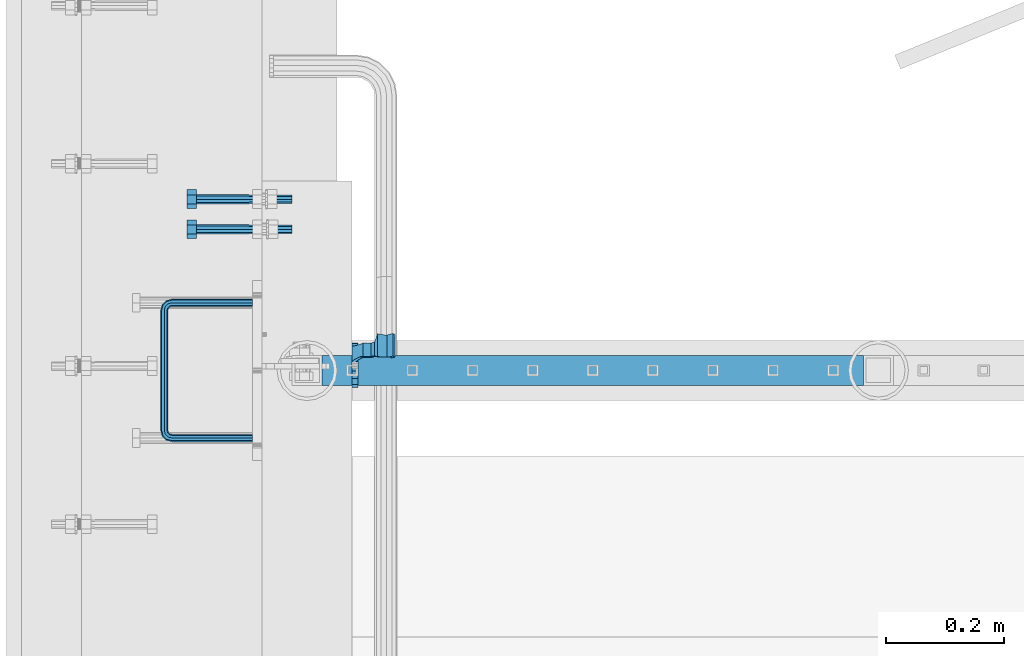
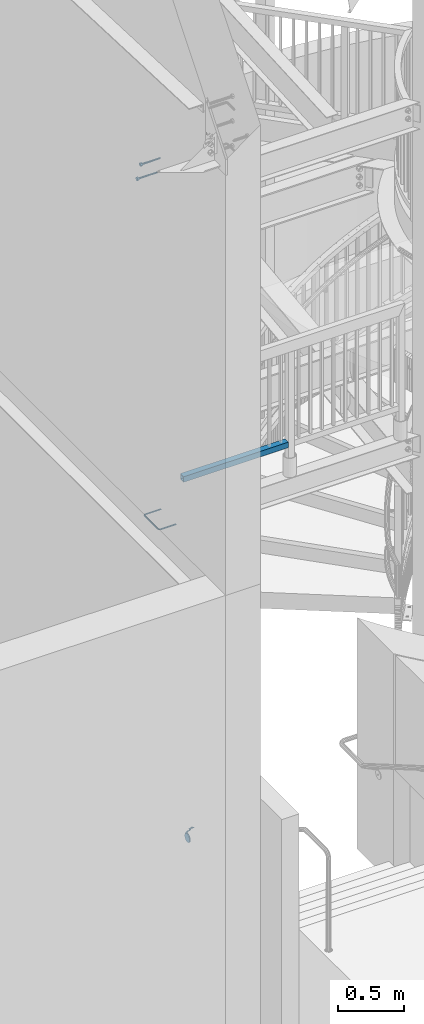
# One storey, part 456 of 975: 5 beams.
"""IFC2X3 building model written with IfcOpenShell, lengths in millimetres."""

import ifcopenshell
import ifcopenshell.guid

model = None  # the IFC model being written
_history = None  # IfcOwnerHistory: only IFC2X3 demands one
_inside = {}  # id of a spatial element -> (the spatial element, [elements in it])
_under = {}  # id of a project, library or spatial element -> (it, [spatial elements below it])
_declared = {}  # id of a project -> (the project, [libraries it declares])
_typed = {}  # id of a type object -> (the type object, [elements of that type])
_made_of = {}  # id of a material, layer set ... -> (it, [elements and type objects made of it])


def new_model(schema):
    """Start an empty IFC model of exactly this schema.

    Asked for "IFC4X3", IfcOpenShell would pick the latest addendum, in which some entities
    have other attributes; the version numbers below select the first issue.
    IFC2X3 requires an IfcOwnerHistory on every rooted entity: one is made here for all.
    """
    global model, _history
    if schema == "IFC4X3":
        model = ifcopenshell.file(schema_version=(4, 3, 0, 0))
    else:
        model = ifcopenshell.file(schema=schema)
    _inside.clear()
    _under.clear()
    _declared.clear()
    _typed.clear()
    _made_of.clear()
    _history = None
    if model.schema == "IFC2X3":
        org = make("IfcOrganization", Name="unknown")
        user = make(
            "IfcPersonAndOrganization",
            ThePerson=make("IfcPerson", FamilyName="unknown"),
            TheOrganization=org,
        )
        app = make(
            "IfcApplication",
            ApplicationDeveloper=org,
            Version="unknown",
            ApplicationFullName="unknown",
            ApplicationIdentifier="unknown",
        )
        _history = make(
            "IfcOwnerHistory",
            OwningUser=user,
            OwningApplication=app,
            ChangeAction="ADDED",
            CreationDate=0,
        )
    return model


def make(cls, **values):
    """One entity of the class cls with the attributes given. An attribute that is None is left unset."""
    return model.create_entity(
        cls, **{name: value for name, value in values.items() if value is not None}
    )


def rooted(cls, **values):
    """An entity with a GlobalId (a new one), such as an element, a storey or a relation."""
    return make(cls, GlobalId=ifcopenshell.guid.new(), OwnerHistory=_history, **values)


def si_unit(unit_type, name, prefix=None):
    """IfcSIUnit, for example si_unit("LENGTHUNIT", "METRE", prefix="MILLI")."""
    return make("IfcSIUnit", UnitType=unit_type, Prefix=prefix, Name=name)


def assignment(units):
    """IfcUnitAssignment: the units of a project."""
    return None if units is None else make("IfcUnitAssignment", Units=units)


def point(xyz):
    """IfcCartesianPoint."""
    return None if xyz is None else make("IfcCartesianPoint", Coordinates=xyz)


def direction(xyz):
    """IfcDirection."""
    return None if xyz is None else make("IfcDirection", DirectionRatios=xyz)


def frame(location, z_axis=None, x_axis=None):
    """IfcAxis2Placement3D, a coordinate frame: its origin and axes. An axis left out is left unset."""
    return make(
        "IfcAxis2Placement3D",
        Location=point(location),
        Axis=direction(z_axis),
        RefDirection=direction(x_axis),
    )


def origin_with_axes():
    """The frame at (0, 0, 0) with the z axis (0, 0, 1) and the x axis (1, 0, 0) written out."""
    return frame((0.0, 0.0, 0.0), z_axis=(0.0, 0.0, 1.0), x_axis=(1.0, 0.0, 0.0))


def place(relative_to, where):
    """IfcLocalPlacement: puts the frame where relative to a parent placement (None: the world)."""
    return make(
        "IfcLocalPlacement", PlacementRelTo=relative_to, RelativePlacement=where
    )


def context(
    kind, dimensions, precision=None, world=None, true_north=None, identifier=None
):
    """IfcGeometricRepresentationContext, for example the 3D "Model" context."""
    return make(
        "IfcGeometricRepresentationContext",
        ContextIdentifier=identifier,
        ContextType=kind,
        CoordinateSpaceDimension=dimensions,
        Precision=precision,
        WorldCoordinateSystem=world,
        TrueNorth=true_north,
    )


def subcontext(parent, identifier, kind, view, scale=None):
    """IfcGeometricRepresentationSubContext, for example "Body" below "Model"."""
    return make(
        "IfcGeometricRepresentationSubContext",
        ContextIdentifier=identifier,
        ContextType=kind,
        ParentContext=parent,
        TargetScale=scale,
        TargetView=view,
    )


def project(units=None, contexts=None):
    """IfcProject with its units and contexts."""
    return rooted(
        "IfcProject",
        Name="project",
        RepresentationContexts=contexts,
        UnitsInContext=assignment(units),
    )


def spatial(cls, under=None, at=None, **own):
    """A site, building, storey or space (cls), placed at a placement, below another one or the project."""
    s = rooted(cls, ObjectPlacement=at, **own)
    if under is not None:
        _under.setdefault(under.id(), (under, []))[1].append(s)
    return s


def faces_of(points, faces, orient=None, outer=None):
    """IfcFace entities. A face is a list of loops; a loop is a list of indices into points, from 0.

    orient and outer hold one flag for each loop. By default every Orientation is true, the
    first loop of a face is its IfcFaceOuterBound and the others are IfcFaceBound.
    """
    made = []
    for i, loops in enumerate(faces):
        bounds = []
        for j, loop in enumerate(loops):
            is_outer = j == 0 if outer is None else outer[i][j]
            bounds.append(
                make(
                    "IfcFaceOuterBound" if is_outer else "IfcFaceBound",
                    Bound=make("IfcPolyLoop", Polygon=[points[k] for k in loop]),
                    Orientation=True if orient is None else orient[i][j],
                )
            )
        made.append(make("IfcFace", Bounds=bounds))
    return made


def faceted_brep(points, faces, orient=None, outer=None, voids=None):
    """IfcFacetedBrep: a solid bounded by flat faces; with voids (closed shells), ...WithVoids."""
    shared = [point(p) for p in points]
    hull = make("IfcClosedShell", CfsFaces=faces_of(shared, faces, orient, outer))
    if voids is None:
        return make("IfcFacetedBrep", Outer=hull)
    return make(
        "IfcFacetedBrepWithVoids",
        Outer=hull,
        Voids=[
            make(cls, CfsFaces=faces_of(shared, fs, o, b)) for cls, fs, o, b in voids
        ],
    )


def shape(context_of_items, identifier, shape_type, items):
    """IfcShapeRepresentation: the items that make up one representation, for example the "Body"."""
    return make(
        "IfcShapeRepresentation",
        ContextOfItems=context_of_items,
        RepresentationIdentifier=identifier,
        RepresentationType=shape_type,
        Items=items,
    )


def material(Name=None, Category=None):
    """IfcMaterial."""
    return make("IfcMaterial", Name=Name, Category=Category)


def made_of(thing, what):
    """Note that an element or type object is made of a material, layer set ...; save() writes the relation."""
    if what is not None:
        _made_of.setdefault(what.id(), (what, []))[1].append(thing)
    return thing


def type_object(cls, material=None, **own):
    """A type object (cls), such as IfcWallType, which elements share."""
    return made_of(rooted(cls, **own), material)


def element(
    cls,
    number,
    at=None,
    inside=None,
    cuts=None,
    type_object=None,
    material=None,
    context=None,
    identifier="Body",
    shape_type=None,
    held_by="IfcProductDefinitionShape",
    body=None,
    shapes=None,
    **own,
):
    """One element of the class cls, such as IfcWall. Its Tag is "e" and its number.

    at: its placement. inside: the storey or other place that contains it. cuts: it is an
    opening in that element (IfcRelVoidsElement). A single representation is given by context,
    identifier, shape_type and body (its items); several are given by shapes. held_by: the class
    of the entity that holds the representations. save() writes the other relations.
    """
    e = rooted(cls, Tag="e%d" % number, ObjectPlacement=at, **own)
    if body is not None:
        shapes = [shape(context, identifier, shape_type, body)]
    if shapes is not None:
        e.Representation = make(held_by, Representations=shapes)
    if inside is not None:
        _inside.setdefault(inside.id(), (inside, []))[1].append(e)
    if cuts is not None:
        rooted(
            "IfcRelVoidsElement", RelatingBuildingElement=cuts, RelatedOpeningElement=e
        )
    if type_object is not None:
        _typed.setdefault(type_object.id(), (type_object, []))[1].append(e)
    return made_of(e, material)


def aggregate(whole, parts):
    """IfcRelAggregates: a whole, such as a stair, and the parts it consists of."""
    return rooted("IfcRelAggregates", RelatingObject=whole, RelatedObjects=parts)


def save(model, path):
    """Write the relations noted so far, then the file.

    IfcRelAggregates (storeys below a building ...), IfcRelContainedInSpatialStructure (elements
    in a storey), IfcRelDefinesByType, IfcRelAssociatesMaterial and IfcRelDeclares: one each for
    every whole, place, type object, material and project.
    """
    for whole, parts in _under.values():
        aggregate(whole, parts)
    for where, things in _inside.values():
        rooted(
            "IfcRelContainedInSpatialStructure",
            RelatedElements=things,
            RelatingStructure=where,
        )
    for kind, things in _typed.values():
        rooted("IfcRelDefinesByType", RelatedObjects=things, RelatingType=kind)
    for what, things in _made_of.values():
        rooted("IfcRelAssociatesMaterial", RelatedObjects=things, RelatingMaterial=what)
    for by, libraries in _declared.values():
        rooted("IfcRelDeclares", RelatingContext=by, RelatedDefinitions=libraries)
    model.write(path)


model = new_model("IFC2X3")

# Units and contexts
model_context = context("Model", 3, precision=1e-05, world=origin_with_axes())
body_context = subcontext(model_context, "Body", "Model", "MODEL_VIEW")
ifc_project = project(units=[si_unit("LENGTHUNIT", "METRE", prefix="MILLI"), si_unit("AREAUNIT", "SQUARE_METRE"), si_unit("VOLUMEUNIT", "CUBIC_METRE"), si_unit("MASSUNIT", "GRAM", prefix="KILO"), si_unit("TIMEUNIT", "SECOND"), si_unit("PLANEANGLEUNIT", "RADIAN"), si_unit("SOLIDANGLEUNIT", "STERADIAN"), si_unit("THERMODYNAMICTEMPERATUREUNIT", "DEGREE_CELSIUS"), si_unit("LUMINOUSINTENSITYUNIT", "LUMEN")], contexts=[model_context])

# Site, building, storey
site_placement = place(None, origin_with_axes())
site = spatial("IfcSite", under=ifc_project, at=site_placement, CompositionType="ELEMENT")
building_placement = place(site_placement, origin_with_axes())
building = spatial("IfcBuilding", under=site, at=building_placement, Name="Undefined", CompositionType="ELEMENT")
storey_placement = place(building_placement, origin_with_axes())
storey = spatial("IfcBuildingStorey", under=building, at=storey_placement, Name="Undefined", CompositionType="ELEMENT", Elevation=0.0)

# Beams
ifc_material_1 = material()
beam_type_1 = type_object("IfcBeamType", Name="HSS2X2X.188_TUBES", PredefinedType="NOTDEFINED")
beam_1_placement = place(storey_placement, frame((30035.4999840149, 1364.89231756838, 4229.10021228673), z_axis=(5.69299999915529e-06, 0.999999999983795, 0.0), x_axis=(0.999999999983699, -5.6929999999029e-06, -4.37999999618523e-07)))
element("IfcBeam", 1, at=beam_1_placement, inside=storey, type_object=beam_type_1, material=ifc_material_1, Name="HANDRAIL", ObjectType="HSS2X2X.188_TUBES", context=body_context, shape_type="Brep", body=[
    faceted_brep([(25.4001425128263, 20.6374999999998, -20.6375000000021), (25.4001244344508, -20.6375000000044, -20.6375000000025), (940.579801494787, -20.6375000000808, -20.6375000000469), (940.579790102809, 20.6374999999234, -20.6375000000467), (25.3998894558863, -20.6375000000044, 20.6375), (940.579566516219, -20.6375000000808, 20.6374999999555), (25.3999075342581, 20.6374999999998, 20.6375000000003), (940.579555124245, 20.6374999999234, 20.6374999999559), (25.4001717116989, 25.3999999999996, -25.4000000000026), (25.3998825073104, 25.4000000000005, 25.4000000000005), (940.579526696874, 25.3999999999232, 25.3999999999562), (940.579815901263, 25.3999999999232, -25.4000000000469), (25.3998602570064, -25.4000000000033, 25.4000000000001), (940.579540717765, -25.4000000000815, 25.399999999956), (25.4001494613913, -25.4000000000042, -25.4000000000028), (940.579829922153, -25.4000000000806, -25.4000000000474)], [[[0, 1, 2, 3]], [[1, 4, 5, 2]], [[4, 6, 7, 5]], [[6, 0, 3, 7]], [[8, 9, 10, 11]], [[9, 12, 13, 10]], [[12, 14, 15, 13]], [[14, 8, 11, 15]], [[13, 15, 11, 10], [5, 7, 3, 2]], [[14, 12, 9, 8], [6, 4, 1, 0]]]),
])
ifc_material_2 = material(Name="STEEL/A36")
beam_type_2 = type_object("IfcBeamType", PredefinedType="NOTDEFINED")
beam_2_placement = place(storey_placement, frame((30121.225030483, 1373.95484456894, 883.216794476958), z_axis=(0.0, -0.863778825965781, 0.50387115398004), x_axis=(-0.999999999999998, 6.90000001668524e-08, 0.0)))
element("IfcBeam", 2, at=beam_2_placement, inside=storey, type_object=beam_type_2, material=ifc_material_2, Name="WALL BRACKET", context=body_context, shape_type="Brep", body=[
    faceted_brep([(1.2732925824821e-11, -14.5802387731151, 35.1998101887366), (0.0, -26.940768363208, 26.9407683632162), (9.52499999999418, -26.9407683632098, 26.940768363238), (9.52500000000691, -14.5802387731169, 35.1998101887584), (0.0, 0.0, 38.0999984741211), (9.52500000001783, -1.13686837721616e-11, 38.1000000001295), (3.27418092638254e-11, 14.5802387730973, 35.1998101888166), (9.5250000000251, 14.580238773096, 35.1998101888312), (3.45607986673713e-11, 26.9407683631939, 26.9407683633472), (9.52500000002692, 26.9407683631925, 26.9407683633617), (3.27418092638254e-11, 35.1998101886679, 14.5802387732328), (9.5250000000251, 35.1998101886661, 14.580238773262), (2.36468622460961e-11, 38.0999999999908, 8.73114913702011e-11), (9.52500000001783, 38.099999999989, 1.23691279441118e-10), (1.45519152283669e-11, 35.1998101886752, -14.5802387730655), (9.52500000000509, 35.1998101886734, -14.5802387730364), (1.81898940354586e-12, 26.9407683632071, -26.9407683632162), (9.52499999999418, 26.9407683632057, -26.9407683631944), (-1.09139364212751e-11, 14.5802387731146, -35.1998101887511), (9.52499999997963, 14.5802387731133, -35.199810188722), (0.0, 0.0, -38.0999984741211), (9.52499999996871, 7.73070496506989e-12, -38.1000000000931), (-2.91038304567337e-11, -14.5802387730978, -35.1998101888239), (9.52499999996326, -14.5802387730996, -35.1998101888021), (-3.27418092638254e-11, -26.9407683631948, -26.9407683633617), (9.52499999995962, -26.9407683631966, -26.9407683633399), (-1.09139364212751e-11, -35.1998101886752, 14.5802387730655), (-3.09228198602796e-11, -35.1998101886688, -14.5802387732401), (-2.36468622460961e-11, -38.0999999999917, -9.45874489843845e-11), (5.15916151986676, -35.4440470179043, 13.3523773160632), (5.45819836063492, -35.1998101886761, 14.5802387730728), (9.52499999997235, -38.0999999999935, -7.27595761418343e-11), (9.52500000450709, -35.4440470179088, 13.3523773160487), (7.2371100059845, -33.7468932558072, 16.754682627492), (9.52500000451801, -33.7468932557954, 16.7546826275138), (9.52500000445798, -35.4440462189814, -13.3523813326392), (9.52500000445798, -33.7468952491577, -16.7546796443567), (7.23710890894472, -33.7468952491804, -16.7546796443348), (5.4581995298613, -35.1998101886693, -14.5802387732328), (5.15916356880916, -35.4440462189727, -13.3523813326829), (9.52500000445434, -31.8782721836319, -20.5007300630459), (-59.362980674241, -68.3509998739587, -22.2250071919989), (-59.3629824602704, -68.3509998769764, 22.2249928081292), (-62.5376644231455, -64.8016283221027, 22.2249926808072), (-62.537662637118, -64.8016283190846, -22.2250073193209), (-56.0009815912945, -61.6535496682918, -19.3956727407494), (-56.000981591309, -64.8016260898362, -22.2250068172871), (-56.0009815912999, -61.6535497228529, -22.225007056426), (-51.9930489428643, -64.8016260898294, -22.2250068955836), (-33.6296835776757, -67.3248053616639, 22.2249938423338), (-32.8101777262855, -64.8016307488883, 22.2249938754467), (-39.3127739489937, -64.9523614530367, 22.2249936141088), (-33.6296817914808, -67.3248053586817, -22.2250061577943), (-39.3127721627934, -64.9523614499894, -22.225006386012), (-32.8101744278647, -64.8016260897953, -22.2250061246668), (-49.8281991999065, -63.7590301286368, -21.2879735671377), (-49.8282009033755, -63.7590301315527, 21.1053320839419), (-51.9930604234723, -64.8016307617759, 22.2249931045444), (-56.0005504677993, -61.6533412357799, 22.2249929437239), (-56.0009815912108, -64.8016307465336, 22.0423691210235), (-56.000981591209, -61.6535489237508, 19.2130313848393), (-50.6240365928552, -59.0640022148641, -17.068316644014), (-50.62403795721, -59.0640022171988, 16.8856769420818), (-37.4819831736677, -60.5563585436898, -18.4095720806508), (-37.4847968100603, -60.5551871533557, 18.2258790235646), (-36.5628445055427, -60.9400583240672, -18.7544223061341), (-36.5628460054704, -60.940058326571, 18.5717818924459), (-35.666111145687, -58.1791078124638, -16.2730176894474), (-35.6661124461261, -58.1791078147403, 16.0903783233516), (-31.1370094513986, -59.6501218585477, -17.5950917468435), (-34.0669059000666, -55.6169453021639, -13.9702738136984), (-28.6196526953099, -55.6169453021544, -13.9702738136766), (-3.23293649958759, -48.4467136455532, -12.207101610089), (-26.7505137989156, -48.4467136455951, -12.207101610169), (-23.8996249546344, -46.7958293195065, -12.4984337370406), (-15.4698233557392, -46.4839007520641, -12.5534798790104), (-13.5258434309762, -46.892085709494, -12.4814473386505), (-10.0158521010289, -46.8359503118018, -12.4913535716478), (-6.87329468697135, -45.2714940850042, -12.7674337020799), (-0.974477882295105, -40.4536660763902, -13.6176374740317), (6.55353226544685, -40.4536660763761, -13.6176374740171), (-3.86099217626361, -48.9596748667777, -12.3332396499609), (-8.88876733573125, -51.4626471867787, -12.9487248158839), (-14.5043997770172, -51.5524581665836, -12.9708094891394), (-16.4483797087032, -51.1442732091714, -12.8704361113705), (-22.5793200272747, -51.3711368440199, -12.9262222664329), (-27.8885295453638, -54.4455783048938, -13.6822326695547), (-31.199579073018, -51.0230653028852, -12.840630880346), (-8.88876836899726, -51.4626471885831, 12.7660892544445), (-14.504400812064, -51.5524581683962, 12.7881739076765), (-16.4483807356864, -51.1442732109658, 12.6878006207626), (-22.5793210587417, -51.3711368458225, 12.7435867252934), (-27.8885306375905, -54.4455783068047, 13.4995964439586), (-31.1370108580904, -59.6501218610088, 17.4124518226672), (-28.6196556343875, -55.6169482259406, 13.7876380457747), (-34.0669088391423, -55.6169482259506, 13.7876380457601), (-31.1995800976092, -51.0230653046779, 12.6579954166664), (-26.7505191794698, -48.4467161992197, 12.0244673476045), (-23.8996259517189, -46.7958293212487, 12.3158002822529), (-15.4698243572475, -46.4839007538158, 12.3708464917727), (-13.5258444266965, -46.8920857112348, 12.2988138630608), (-10.0158530975405, -46.8359503135416, 12.3087201082308), (-6.87329570566908, -45.2714940867804, 12.5848005773296), (4.1273854062656, -36.2867456275421, -11.663012015495), (9.5250000044598, -36.286745627533, -11.6630120154732), (1.90728621943163, -38.0999997439571, -4.32692468166351e-06), (9.43529700414729, -38.0999997439435, -4.32690285379067e-06), (4.12738132945015, -36.2867481933758, 11.6630037605864), (9.52500000449982, -36.2867481933667, 11.663003760601), (9.52500000452892, -31.8782708408467, 20.5007332856403), (9.52500000445252, -31.8782722112123, -21.3428951777532), (1.9072884344514, -38.0999984248297, -14.9620414646415), (-0.974482456142141, -40.4536689261299, 13.4350048896813), (1.90728340723763, -38.1000015568025, 14.7794093744233), (9.52500000452892, -31.8782708139925, 21.3207127303758), (9.43529858219699, -38.099998424816, -14.9620414646197), (6.55352759261223, -40.4536689261167, 13.4350048897031), (-3.23294036661173, -48.4467161991774, 12.0244673476845), (-3.86099316006766, -48.9596748684935, 12.1506046457653), (9.43529336634128, -38.1000015567884, 14.7794093744451)], [[[0, 1, 2, 3]], [[4, 0, 3, 5]], [[6, 4, 5, 7]], [[8, 6, 7, 9]], [[10, 8, 9, 11]], [[12, 10, 11, 13]], [[14, 12, 13, 15]], [[16, 14, 15, 17]], [[18, 16, 17, 19]], [[20, 18, 19, 21]], [[22, 20, 21, 23]], [[24, 22, 23, 25]], [[26, 1, 0, 4, 6, 8, 10, 12, 14, 16, 18, 20, 22, 24, 27, 28]], [[29, 30, 26, 28, 31, 32]], [[33, 34, 2, 1, 26, 30]], [[32, 31, 35, 36, 25, 23, 21, 19, 17, 15, 13, 11, 9, 7, 5, 3, 2, 34]], [[37, 38, 27, 24, 25, 36]], [[39, 35, 31, 28, 27, 38]], [[40, 37, 36]], [[41, 42, 43, 44]], [[45, 46, 47]], [[41, 44, 47, 46, 48]], [[49, 50, 51]], [[52, 53, 54]], [[51, 53, 52, 49]], [[55, 53, 51, 56]], [[42, 41, 48, 55, 56, 57]], [[58, 43, 42, 57, 59]], [[58, 59, 60]], [[61, 45, 47, 44, 43, 58, 60, 62]], [[63, 61, 62, 64]], [[65, 63, 64, 66]], [[67, 65, 66, 68]], [[69, 54, 53, 55, 48, 46, 45, 61, 63, 65, 67, 70, 71]], [[72, 73, 74, 75, 76, 77, 78, 79, 80]], [[81, 82, 83, 84, 85, 86, 71, 70, 87, 73, 72]], [[83, 82, 88, 89]], [[84, 83, 89, 90]], [[85, 84, 90, 91]], [[86, 85, 91, 92]], [[93, 69, 71, 86, 92, 94]], [[49, 52, 54, 69, 93, 50]], [[94, 95, 68, 66, 64, 62, 60, 59, 57, 56, 51, 50, 93]], [[87, 70, 67, 68, 95, 96]], [[74, 73, 87, 96, 97, 98]], [[75, 74, 98, 99]], [[76, 75, 99, 100]], [[77, 76, 100, 101]], [[78, 77, 101, 102]], [[103, 104, 35, 39]], [[103, 105, 106, 104]], [[105, 107, 108, 106]], [[108, 107, 29, 32]], [[109, 34, 33]], [[29, 107, 105, 103, 39, 38, 37, 40, 110, 111, 79, 78, 102, 112, 113, 114, 109, 33, 30]], [[111, 110, 115]], [[80, 79, 111, 115]], [[116, 117, 118, 81, 72, 80, 115, 119]], [[82, 81, 118, 88]], [[117, 97, 96, 95, 94, 92, 91, 90, 89, 88, 118]], [[116, 112, 102, 101, 100, 99, 98, 97, 117]], [[119, 113, 112, 116]], [[113, 119, 114]], [[115, 110, 40, 36, 35, 104, 106, 108, 32, 34, 109, 114, 119]]]),
])
ifc_material_3 = material(Name="STEEL/F1554-36")
beam_type_3 = type_object("IfcBeamType", PredefinedType="NOTDEFINED")
beam_3_placement = place(storey_placement, frame((29937.0748508932, 1654.53464552512, 6890.89044574241), z_axis=(-7.0905516622588e-09, -0.0430877640020049, 0.999071291046494), x_axis=(-0.999999999999998, 6.90000001668524e-08, 0.0)))
element("IfcBeam", 3, at=beam_3_placement, inside=storey, type_object=beam_type_3, material=ifc_material_3, Name="HEADED_ANCHOR_BOLT", context=body_context, shape_type="Brep", body=[
    faceted_brep([(88.900000064019, -7.94000009583215, -13.7499999799147), (88.9000000184824, 7.94000001861696, -13.7499999799138), (104.775000018315, 7.94000006417082, -13.7499999302891), (104.775000063852, -7.9400000502792, -13.74999993029), (88.9000000438027, -15.880000153059, 2.00925569515675e-08), (104.775000043643, -15.8800001075042, 6.9716406869702e-08), (88.8999999780608, -7.94000009583488, 13.7500000200998), (104.774999977893, -7.94000005028101, 13.7500000697237), (88.8999999325279, 7.94000001861514, 13.7500000201007), (104.774999932361, 7.940000064169, 13.7500000697246), (88.8999999527368, 15.8800000758411, 2.00943759409711e-08), (104.774999952569, 15.8800001213949, 6.97191353538074e-08), (88.9000000119959, 3.78780480527439, -7.86545778426807), (88.8999999957159, 6.82538844544797, -5.4430656647246), (88.8999999799416, 8.51112018845743, -1.94260763148395), (88.8999999677944, 8.51112018845652, 1.94260767167179), (88.8999999616899, 6.82538844544615, 5.44306570491244), (88.8999999628249, 3.78780480527257, 7.86545782445592), (88.8999999709849, -3.86089595849626e-08, 8.72999956233434), (88.8999999845473, -3.7878048824914, 7.8654578244541), (88.9000000008309, -6.82538852266407, 5.44306570491153), (88.9000000166052, -8.51112026567444, 1.94260767166998), (88.9000000287488, -8.51112026567353, -1.94260763148577), (88.9000000348606, -6.82538852266407, -5.44306566472642), (88.9000000337182, -3.78780488248958, -7.86545778426898), (88.9000000255583, -3.86080500902608e-08, -8.72999952214832), (104.775000025395, 6.94581103743985e-09, -8.72999947252447), (104.775000011829, 3.78780485082825, -7.86545773464422), (104.774999995549, 6.82538849100092, -5.44306561510075), (104.774999979774, 8.51112023401038, -1.9426075818601), (104.774999967627, 8.51112023401038, 1.94260772129564), (104.774999961523, 6.82538849100092, 5.44306575453629), (104.774999962658, 3.78780485082643, 7.86545787407977), (104.774999970818, 6.94399204803631e-09, 8.7299996119591), (104.77499998438, -3.78780483693754, 7.86545787407886), (104.775000000664, -6.82538847711112, 5.44306575453538), (104.775000016438, -8.51112022012057, 1.94260772129473), (104.775000028581, -8.51112022012057, -1.94260758186101), (104.775000034693, -6.82538847711021, -5.44306561510166), (104.775000033551, -3.78780483693663, -7.86545773464422), (-2.99107341561466e-07, -5.61266007567065, -5.61266007566792), (-1.09139364212751e-11, 1.81898940354586e-12, -7.9375), (104.774999998099, 1.2732925824821e-11, -7.93750000004547), (104.774999998092, -5.612660075657, -5.6126600757143), (2.99089151667431e-07, 5.61266007567428, -5.61266007566792), (104.774999998102, 5.61266007568156, -5.61266007571339), (4.22980519942939e-07, 7.93750000001091, 0.0), (104.77499999811, 7.93750000001364, -4.36557456851006e-11), (2.99089151667431e-07, 5.61266007567428, 5.61266007566792), (104.774999998102, 5.61266007568065, 5.61266007562517), (-1.09139364212751e-11, 1.81898940354586e-12, 7.9375), (104.774999998095, 1.18234311230481e-11, 7.93749999995816), (-2.99107341561466e-07, -5.61266007567065, 5.61266007566792), (104.774999998088, -5.61266007565791, 5.61266007562426), (-4.22995071858168e-07, -7.93750000000728, 0.0), (104.774999998088, -7.93749999999, -4.45652403868735e-11), (0.00624994074678398, 5.05157085007704, 5.05157081110701), (0.00624993484598235, 5.2777977543883e-09, 7.14399996631164), (0.00624996711121639, -5.05157083952145, 5.05157081110519), (0.00625001864682417, -7.14399999472516, -3.36940502165817e-08), (0.00625005926485755, -5.05157083952145, -5.05157087849329), (0.00625006516929716, 5.27870724909008e-09, -7.1440000336961), (0.00625003290042514, 5.05157085007795, -5.05157087849238), (0.00624998136845534, 7.14400000528167, -3.36922312271781e-08), (-73.0249999592124, 5.05157065939329, -5.0515715445581), (-73.0249999269472, -1.85405951924622e-07, -7.14400069976364), (-73.0249999328516, -5.0515710302052, -5.05157154455992), (-73.0249999734697, -7.14400018541073, -6.9975976657588e-07), (-73.0250000250016, -5.05157103020611, 5.05157014504039), (-73.0250000572705, -1.85406861419324e-07, 7.1439993002441), (-73.0250000513661, 5.05157065939238, 5.05157014503948), (-73.025000010748, 7.14399981459792, -6.99758857081179e-07)], [[[0, 1, 2, 3]], [[4, 0, 3, 5]], [[6, 4, 5, 7]], [[8, 6, 7, 9]], [[10, 8, 9, 11]], [[1, 0, 4, 6, 8, 10], [12, 13, 14, 15, 16, 17, 18, 19, 20, 21, 22, 23, 24, 25]], [[12, 25, 26, 27]], [[13, 12, 27, 28]], [[14, 13, 28, 29]], [[15, 14, 29, 30]], [[16, 15, 30, 31]], [[17, 16, 31, 32]], [[18, 17, 32, 33]], [[19, 18, 33, 34]], [[20, 19, 34, 35]], [[21, 20, 35, 36]], [[22, 21, 36, 37]], [[23, 22, 37, 38]], [[24, 23, 38, 39]], [[25, 24, 39, 26]], [[7, 5, 3, 2, 11, 9], [38, 37, 36, 35, 34, 33, 32, 31, 30, 29, 28, 27, 26, 39]], [[1, 10, 11, 2]], [[40, 41, 42, 43]], [[41, 44, 45, 42]], [[44, 46, 47, 45]], [[46, 48, 49, 47]], [[48, 50, 51, 49]], [[50, 52, 53, 51]], [[52, 54, 55, 53]], [[42, 45, 47, 49, 51, 53, 55, 43]], [[54, 40, 43, 55]], [[52, 50, 48, 46, 44, 41, 40, 54], [56, 57, 58, 59, 60, 61, 62, 63]], [[64, 65, 66, 67, 68, 69, 70, 71]], [[70, 69, 57, 56]], [[71, 70, 56, 63]], [[64, 71, 63, 62]], [[65, 64, 62, 61]], [[66, 65, 61, 60]], [[67, 66, 60, 59]], [[68, 67, 59, 58]], [[69, 68, 58, 57]]]),
])
beam_4_placement = place(storey_placement, frame((29937.0748356033, 1603.79133963999, 7053.95547011594), z_axis=(-7.0905516622588e-09, -0.0430877640020049, 0.999071291046494), x_axis=(-0.999999999999998, 6.90000001668524e-08, 0.0)))
element("IfcBeam", 4, at=beam_4_placement, inside=storey, type_object=beam_type_3, material=ifc_material_3, Name="HEADED_ANCHOR_BOLT", context=body_context, shape_type="Brep", body=[
    faceted_brep([(88.9000000184824, 7.94000001861696, -13.7499999799138), (88.8999999527368, 15.8800000758411, 2.00943759409711e-08), (104.774999952569, 15.8800001213949, 6.97191353538074e-08), (104.775000018315, 7.94000006417082, -13.7499999302891), (88.900000064019, -7.94000009583215, -13.7499999799147), (104.775000063852, -7.9400000502792, -13.74999993029), (88.9000000438027, -15.880000153059, 2.00925569515675e-08), (104.775000043643, -15.8800001075042, 6.9716406869702e-08), (88.8999999780608, -7.94000009583488, 13.7500000200998), (104.774999977893, -7.94000005028101, 13.7500000697237), (88.8999999325279, 7.94000001861514, 13.7500000201007), (104.774999932361, 7.940000064169, 13.7500000697246), (88.9000000119959, 3.78780480527439, -7.86545778426807), (88.8999999957159, 6.82538844544797, -5.4430656647246), (88.8999999799416, 8.51112018845743, -1.94260763148395), (88.8999999677944, 8.51112018845652, 1.94260767167179), (88.8999999616899, 6.82538844544615, 5.44306570491244), (88.8999999628249, 3.78780480527257, 7.86545782445592), (88.8999999709849, -3.86089595849626e-08, 8.72999956233434), (88.8999999845473, -3.7878048824914, 7.8654578244541), (88.9000000008309, -6.82538852266407, 5.44306570491153), (88.9000000166052, -8.51112026567444, 1.94260767166998), (88.9000000287488, -8.51112026567353, -1.94260763148577), (88.9000000348606, -6.82538852266407, -5.44306566472642), (88.9000000337182, -3.78780488248958, -7.86545778426898), (88.9000000255583, -3.86080500902608e-08, -8.72999952214832), (104.775000025395, 6.94581103743985e-09, -8.72999947252447), (104.775000011829, 3.78780485082825, -7.86545773464422), (104.774999995549, 6.82538849100092, -5.44306561510075), (104.774999979774, 8.51112023401038, -1.9426075818601), (104.774999967627, 8.51112023401038, 1.94260772129564), (104.774999961523, 6.82538849100092, 5.44306575453629), (104.774999962658, 3.78780485082643, 7.86545787407977), (104.774999970818, 6.94399204803631e-09, 8.7299996119591), (104.77499998438, -3.78780483693754, 7.86545787407886), (104.775000000664, -6.82538847711112, 5.44306575453538), (104.775000016438, -8.51112022012057, 1.94260772129473), (104.775000028581, -8.51112022012057, -1.94260758186101), (104.775000034693, -6.82538847711021, -5.44306561510166), (104.775000033551, -3.78780483693663, -7.86545773464422), (-2.99107341561466e-07, -5.61266007567065, 5.61266007566792), (-4.22995071858168e-07, -7.93750000000728, 0.0), (104.774999998088, -7.93749999999, -4.45652403868735e-11), (104.774999998088, -5.61266007565791, 5.61266007562426), (-1.09139364212751e-11, 1.81898940354586e-12, 7.9375), (104.774999998095, 1.18234311230481e-11, 7.93749999995816), (2.99089151667431e-07, 5.61266007567428, 5.61266007566792), (104.774999998102, 5.61266007568065, 5.61266007562517), (4.22980519942939e-07, 7.93750000001091, 0.0), (104.77499999811, 7.93750000001364, -4.36557456851006e-11), (2.99089151667431e-07, 5.61266007567428, -5.61266007566792), (104.774999998102, 5.61266007568156, -5.61266007571339), (-1.09139364212751e-11, 1.81898940354586e-12, -7.9375), (104.774999998099, 1.2732925824821e-11, -7.93750000004547), (-73.0249999592124, 5.05157065939329, -5.0515715445581), (-73.0249999269472, -1.85405951924622e-07, -7.14400069976364), (-73.0249999328516, -5.0515710302052, -5.05157154455992), (-73.0249999734697, -7.14400018541073, -6.9975976657588e-07), (-73.0250000250016, -5.05157103020611, 5.05157014504039), (-73.0250000572705, -1.85406861419324e-07, 7.1439993002441), (-73.0250000513661, 5.05157065939238, 5.05157014503948), (-73.025000010748, 7.14399981459792, -6.99758857081179e-07), (0.00625003290042514, 5.05157085007795, -5.05157087849238), (0.00625006516929716, 5.27870724909008e-09, -7.1440000336961), (0.00625005926485755, -5.05157083952145, -5.05157087849329), (0.00625001864682417, -7.14399999472516, -3.36940502165817e-08), (0.00624996711121639, -5.05157083952145, 5.05157081110519), (0.00624993484598235, 5.2777977543883e-09, 7.14399996631164), (0.00624994074678398, 5.05157085007704, 5.05157081110701), (0.00624998136845534, 7.14400000528167, -3.36922312271781e-08), (-2.99107341561466e-07, -5.61266007567065, -5.61266007566792), (104.774999998092, -5.612660075657, -5.6126600757143)], [[[0, 1, 2, 3]], [[4, 0, 3, 5]], [[6, 4, 5, 7]], [[8, 6, 7, 9]], [[10, 8, 9, 11]], [[0, 4, 6, 8, 10, 1], [12, 13, 14, 15, 16, 17, 18, 19, 20, 21, 22, 23, 24, 25]], [[12, 25, 26, 27]], [[13, 12, 27, 28]], [[14, 13, 28, 29]], [[15, 14, 29, 30]], [[16, 15, 30, 31]], [[17, 16, 31, 32]], [[18, 17, 32, 33]], [[19, 18, 33, 34]], [[20, 19, 34, 35]], [[21, 20, 35, 36]], [[22, 21, 36, 37]], [[23, 22, 37, 38]], [[24, 23, 38, 39]], [[25, 24, 39, 26]], [[9, 7, 5, 3, 2, 11], [38, 37, 36, 35, 34, 33, 32, 31, 30, 29, 28, 27, 26, 39]], [[1, 10, 11, 2]], [[40, 41, 42, 43]], [[44, 40, 43, 45]], [[46, 44, 45, 47]], [[48, 46, 47, 49]], [[50, 48, 49, 51]], [[52, 50, 51, 53]], [[54, 55, 56, 57, 58, 59, 60, 61]], [[55, 54, 62, 63]], [[56, 55, 63, 64]], [[57, 56, 64, 65]], [[58, 57, 65, 66]], [[59, 58, 66, 67]], [[60, 59, 67, 68]], [[61, 60, 68, 69]], [[54, 61, 69, 62]], [[40, 44, 46, 48, 50, 52, 70, 41], [68, 67, 66, 65, 64, 63, 62, 69]], [[41, 70, 71, 42]], [[53, 51, 49, 47, 45, 43, 42, 71]], [[70, 52, 53, 71]]]),
])
ifc_material_4 = material(Name="STEEL/A706")
beam_type_4 = type_object("IfcBeamType", Name="#4 TIE", PredefinedType="NOTDEFINED")
beam_5_placement = place(storey_placement, frame((29943.4250010286, 1479.29508112653, 3913.1875), z_axis=(0.0, -1.0, 0.0), x_axis=(-0.999999999999998, 6.90000001668524e-08, 0.0)))
element("IfcBeam", 5, at=beam_5_placement, inside=storey, type_object=beam_type_4, material=ifc_material_4, Name="TIE ROD", ObjectType="#4 TIE", context=body_context, shape_type="Brep", body=[
    faceted_brep([(0.0, -6.34999999998763, -3.63797880709171e-12), (0.0, -4.49012806052269, -4.49012806054634), (136.525006144455, -4.49012806053452, -4.49012811661669), (136.525006146271, -6.35000000000036, -5.60821717954241e-08), (0.0, 7.27595761418343e-12, -6.35000000000764), (136.525006143703, 0.0, -6.35000005608254), (0.0, 4.49012806053724, -4.49012806053906), (136.525006144455, 4.49012806053452, -4.49012811661669), (0.0, 6.34999999999491, 5.45696821063757e-12), (136.525006146271, 6.35000000000036, -5.60821717954241e-08), (0.0, 4.49012806052633, 4.49012806054634), (136.525006148087, 4.49012806053452, 4.49012800445234), (0.0, 0.0, 6.35000000000764), (136.525006148839, 0.0, 6.34999994391819), (0.0, -4.49012806053361, 4.49012806053543), (136.525006148087, -4.49012806053452, 4.49012800445234), (146.050006113442, 0.0, -3.79778399058796), (145.120070138105, -4.49012806053452, -2.1870876464609), (142.875006094308, -6.35000000000036, 1.70147731239558), (140.62994205051, -4.49012806053452, 5.59004227125297), (139.700006075173, 0.0, 7.20073861538003), (140.62994205051, 4.49012806053452, 5.59004227125297), (142.875006094308, 6.35000000000036, 1.70147731239558), (145.120070138105, 4.49012806053452, -2.1870876464609), (151.412093644245, 4.49012806053452, 4.10493592790226), (153.022789998455, 0.0, 3.1749999700296), (147.523528661045, 6.35000000000036, 6.34999992953635), (143.634963677846, 4.49012806053452, 8.59506393117135), (142.024267323636, 0.0, 9.5249998890431), (143.634963677846, -4.49012806053452, 8.59506393117135), (147.523528661045, -6.35000000000036, 6.34999992953635), (151.412093644245, -4.49012806053452, 4.10493592790226), (153.715134021207, 4.49012806053452, 12.6999999465306), (155.575005960673, 0.0, 12.6999999674508), (149.225005960672, 6.35000000000036, 12.6999998960273), (144.734877900137, 4.49012806053452, 12.699999845524), (142.875005960672, 0.0, 12.6999998246056), (144.734877900137, -4.49012806053452, 12.699999845524), (149.225005960671, -6.35000000000036, 12.6999998960273), (153.715134021207, -4.49012806053452, 12.6999999465306), (153.71513173569, -4.49012806053452, 215.900003176369), (149.225003675155, -6.35000000000036, 215.900003125867), (155.575003675155, 0.0, 215.900003197289), (153.71513173569, 4.49012806053452, 215.900003176369), (149.225003675155, 6.35000000000036, 215.900003125867), (144.734875614621, 4.49012806053452, 215.900003075363), (142.875003675155, 0.0, 215.900003054444), (144.734875614621, -4.49012806053452, 215.900003075363), (153.022787648382, 0.0, 225.425002877988), (151.412091300475, -4.49012806053452, 224.495066909199), (147.523526332491, -6.35000000000036, 222.25000288121), (143.634961364508, -4.49012806053452, 220.004938853222), (142.024265016601, 0.0, 219.075002884432), (143.634961364508, 4.49012806053452, 220.004938853222), (147.523526332491, 6.35000000000036, 222.25000288121), (151.412091300475, 4.49012806053452, 224.495066909199), (145.120067985683, 4.49012806053452, 230.787090305822), (146.05000397542, 0.0, 232.397786641635), (142.875003907121, 6.35000000000036, 226.898525367037), (140.629939828559, 4.49012806053452, 223.00996042825), (139.700003838822, 0.0, 221.399264092438), (140.629939828559, -4.49012806053452, 223.00996042825), (142.875003907121, -6.35000000000036, 226.898525367037), (145.120067985683, -4.49012806053452, 230.787090305822), (136.525004282814, 4.49012806053452, 233.090130852819), (136.525004327922, 0.0, 234.950002792285), (136.525004173912, 6.35000000000036, 228.600002792285), (136.52500406501, 4.49012806053452, 224.10987473175), (136.525004019901, 0.0, 222.250002792285), (136.52500406501, -4.49012806053452, 224.10987473175), (136.525004173912, -6.35000000000036, 228.600002792286), (136.525004282814, -4.49012806053452, 233.090130852819), (3.32236731992452e-06, -4.49012806053452, 233.090134164055), (3.21346533382894e-06, -6.35000000000036, 228.60000610352), (3.36747552864836e-06, 0.0, 234.95000610352), (3.32236731992452e-06, 4.49012806053452, 233.090134164055), (3.21346533382894e-06, 6.35000000000036, 228.60000610352), (3.104562892986e-06, 4.49012806053452, 224.109878042986), (3.05945422951481e-06, 0.0, 222.25000610352), (3.104562892986e-06, -4.49012806053452, 224.109878042986)], [[[0, 1, 2, 3]], [[1, 4, 5, 2]], [[4, 6, 7, 5]], [[6, 8, 9, 7]], [[8, 10, 11, 9]], [[10, 12, 13, 11]], [[12, 14, 15, 13]], [[14, 0, 3, 15]], [[14, 12, 10, 8, 6, 4, 1, 0]], [[2, 5, 16, 17]], [[3, 2, 17, 18]], [[15, 3, 18, 19]], [[13, 15, 19, 20]], [[11, 13, 20, 21]], [[9, 11, 21, 22]], [[7, 9, 22, 23]], [[5, 7, 23, 16]], [[23, 24, 25, 16]], [[22, 26, 24, 23]], [[21, 27, 26, 22]], [[20, 28, 27, 21]], [[19, 29, 28, 20]], [[18, 30, 29, 19]], [[17, 31, 30, 18]], [[16, 25, 31, 17]], [[24, 32, 33, 25]], [[26, 34, 32, 24]], [[27, 35, 34, 26]], [[28, 36, 35, 27]], [[29, 37, 36, 28]], [[30, 38, 37, 29]], [[31, 39, 38, 30]], [[25, 33, 39, 31]], [[38, 39, 40, 41]], [[39, 33, 42, 40]], [[33, 32, 43, 42]], [[32, 34, 44, 43]], [[34, 35, 45, 44]], [[35, 36, 46, 45]], [[36, 37, 47, 46]], [[37, 38, 41, 47]], [[40, 42, 48, 49]], [[41, 40, 49, 50]], [[47, 41, 50, 51]], [[46, 47, 51, 52]], [[45, 46, 52, 53]], [[44, 45, 53, 54]], [[43, 44, 54, 55]], [[42, 43, 55, 48]], [[55, 56, 57, 48]], [[54, 58, 56, 55]], [[53, 59, 58, 54]], [[52, 60, 59, 53]], [[51, 61, 60, 52]], [[50, 62, 61, 51]], [[49, 63, 62, 50]], [[48, 57, 63, 49]], [[56, 64, 65, 57]], [[58, 66, 64, 56]], [[59, 67, 66, 58]], [[60, 68, 67, 59]], [[61, 69, 68, 60]], [[62, 70, 69, 61]], [[63, 71, 70, 62]], [[57, 65, 71, 63]], [[70, 71, 72, 73]], [[71, 65, 74, 72]], [[65, 64, 75, 74]], [[64, 66, 76, 75]], [[66, 67, 77, 76]], [[67, 68, 78, 77]], [[68, 69, 79, 78]], [[69, 70, 73, 79]], [[74, 75, 76, 77, 78, 79, 73, 72]]]),
])

save(model, "model.ifc")
